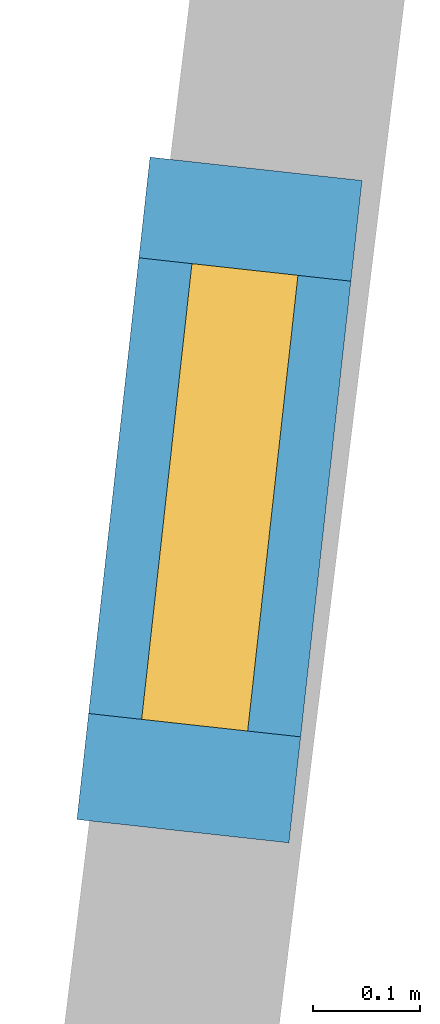
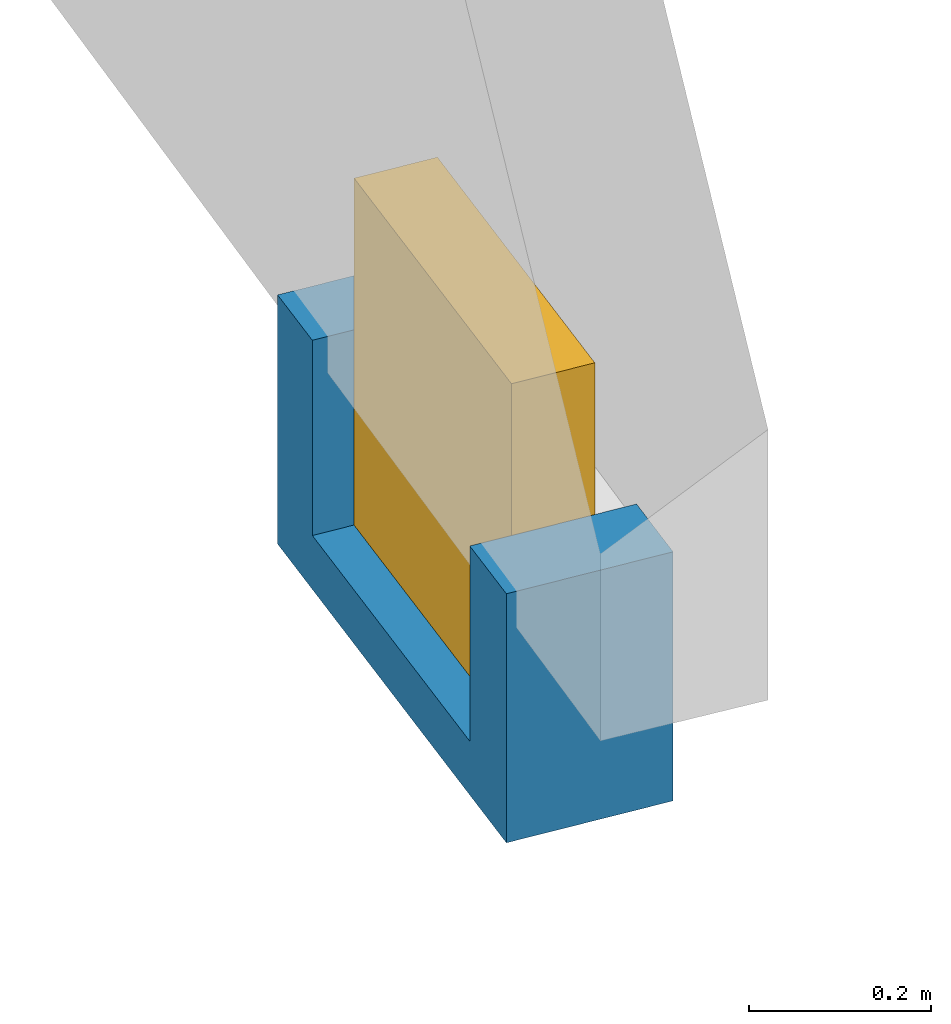
# One storey, part 27 of 27: 1 wall, 1 window, 1 opening.
"""IFC2X3 building model written with IfcOpenShell, lengths in metres."""

import ifcopenshell
import ifcopenshell.guid

model = None  # the IFC model being written
_history = None  # IfcOwnerHistory: only IFC2X3 demands one
_inside = {}  # id of a spatial element -> (the spatial element, [elements in it])
_under = {}  # id of a project, library or spatial element -> (it, [spatial elements below it])
_declared = {}  # id of a project -> (the project, [libraries it declares])
_typed = {}  # id of a type object -> (the type object, [elements of that type])
_made_of = {}  # id of a material, layer set ... -> (it, [elements and type objects made of it])


def new_model(schema):
    """Start an empty IFC model of exactly this schema.

    Asked for "IFC4X3", IfcOpenShell would pick the latest addendum, in which some entities
    have other attributes; the version numbers below select the first issue.
    IFC2X3 requires an IfcOwnerHistory on every rooted entity: one is made here for all.
    """
    global model, _history
    if schema == "IFC4X3":
        model = ifcopenshell.file(schema_version=(4, 3, 0, 0))
    else:
        model = ifcopenshell.file(schema=schema)
    _inside.clear()
    _under.clear()
    _declared.clear()
    _typed.clear()
    _made_of.clear()
    _history = None
    if model.schema == "IFC2X3":
        org = make("IfcOrganization", Name="unknown")
        user = make(
            "IfcPersonAndOrganization",
            ThePerson=make("IfcPerson", FamilyName="unknown"),
            TheOrganization=org,
        )
        app = make(
            "IfcApplication",
            ApplicationDeveloper=org,
            Version="unknown",
            ApplicationFullName="unknown",
            ApplicationIdentifier="unknown",
        )
        _history = make(
            "IfcOwnerHistory",
            OwningUser=user,
            OwningApplication=app,
            ChangeAction="ADDED",
            CreationDate=0,
        )
    return model


def make(cls, **values):
    """One entity of the class cls with the attributes given. An attribute that is None is left unset."""
    return model.create_entity(
        cls, **{name: value for name, value in values.items() if value is not None}
    )


def entity(cls, *values):
    """Any entity or typed value of the class cls, its attributes in the order of the schema. None: left unset."""
    e = model.create_entity(cls)
    for i, value in enumerate(values):
        if value is not None:
            e[i] = value
    return e


def rooted(cls, **values):
    """An entity with a GlobalId (a new one), such as an element, a storey or a relation."""
    return make(cls, GlobalId=ifcopenshell.guid.new(), OwnerHistory=_history, **values)


def si_unit(unit_type, name, prefix=None):
    """IfcSIUnit, for example si_unit("LENGTHUNIT", "METRE", prefix="MILLI")."""
    return make("IfcSIUnit", UnitType=unit_type, Prefix=prefix, Name=name)


def converted_unit(unit_type, name, factor, base, dimensions=None, offset=None):
    """IfcConversionBasedUnit, such as the inch: factor (a typed value) times the base unit."""
    return make(
        "IfcConversionBasedUnit"
        if offset is None
        else "IfcConversionBasedUnitWithOffset",
        ConversionOffset=offset,
        Dimensions=None
        if dimensions is None
        else entity("IfcDimensionalExponents", *dimensions),
        UnitType=unit_type,
        Name=name,
        ConversionFactor=make(
            "IfcMeasureWithUnit", ValueComponent=factor, UnitComponent=base
        ),
    )


def derived_unit(unit_type, elements):
    """IfcDerivedUnit: a product of units, each with its exponent."""
    return make(
        "IfcDerivedUnit",
        Elements=[
            make("IfcDerivedUnitElement", Unit=unit, Exponent=power)
            for unit, power in elements
        ],
        UnitType=unit_type,
    )


def assignment(units):
    """IfcUnitAssignment: the units of a project."""
    return None if units is None else make("IfcUnitAssignment", Units=units)


def point(xyz):
    """IfcCartesianPoint."""
    return None if xyz is None else make("IfcCartesianPoint", Coordinates=xyz)


def direction(xyz):
    """IfcDirection."""
    return None if xyz is None else make("IfcDirection", DirectionRatios=xyz)


def frame(location, z_axis=None, x_axis=None):
    """IfcAxis2Placement3D, a coordinate frame: its origin and axes. An axis left out is left unset."""
    return make(
        "IfcAxis2Placement3D",
        Location=point(location),
        Axis=direction(z_axis),
        RefDirection=direction(x_axis),
    )


def frame_2d(location, x_axis=None):
    """IfcAxis2Placement2D, a coordinate frame in the plane: its origin and x axis."""
    return make(
        "IfcAxis2Placement2D", Location=point(location), RefDirection=direction(x_axis)
    )


def origin():
    """The frame at (0, 0, 0) with its axes left unset."""
    return frame((0.0, 0.0, 0.0))


def origin_2d_with_axis():
    """The frame at (0, 0) in the plane with the x axis (1, 0) written out."""
    return frame_2d((0.0, 0.0), x_axis=(1.0, 0.0))


def place(relative_to, where):
    """IfcLocalPlacement: puts the frame where relative to a parent placement (None: the world)."""
    return make(
        "IfcLocalPlacement", PlacementRelTo=relative_to, RelativePlacement=where
    )


def context(
    kind, dimensions, precision=None, world=None, true_north=None, identifier=None
):
    """IfcGeometricRepresentationContext, for example the 3D "Model" context."""
    return make(
        "IfcGeometricRepresentationContext",
        ContextIdentifier=identifier,
        ContextType=kind,
        CoordinateSpaceDimension=dimensions,
        Precision=precision,
        WorldCoordinateSystem=world,
        TrueNorth=true_north,
    )


def subcontext(parent, identifier, kind, view, scale=None):
    """IfcGeometricRepresentationSubContext, for example "Body" below "Model"."""
    return make(
        "IfcGeometricRepresentationSubContext",
        ContextIdentifier=identifier,
        ContextType=kind,
        ParentContext=parent,
        TargetScale=scale,
        TargetView=view,
    )


def project(units=None, contexts=None):
    """IfcProject with its units and contexts."""
    return rooted(
        "IfcProject",
        Name="project",
        RepresentationContexts=contexts,
        UnitsInContext=assignment(units),
    )


def spatial(cls, under=None, at=None, **own):
    """A site, building, storey or space (cls), placed at a placement, below another one or the project."""
    s = rooted(cls, ObjectPlacement=at, **own)
    if under is not None:
        _under.setdefault(under.id(), (under, []))[1].append(s)
    return s


def polyline(points):
    """IfcPolyline through the points."""
    return make("IfcPolyline", Points=[point(p) for p in points])


def profile(cls, at=None, kind="AREA", **sizes):
    """A parametric profile (cls). Its sizes go by their IFC names, for example OverallWidth=200.0."""
    return make(cls, ProfileType=kind, Position=at, **sizes)


def rectangle(**sizes):
    """IfcRectangleProfileDef."""
    return profile("IfcRectangleProfileDef", **sizes)


def outline(outer, holes=None, kind="AREA"):
    """IfcArbitraryClosedProfileDef: a profile drawn as a closed curve; with holes, ...WithVoids."""
    if holes is None:
        return make("IfcArbitraryClosedProfileDef", ProfileType=kind, OuterCurve=outer)
    return make(
        "IfcArbitraryProfileDefWithVoids",
        ProfileType=kind,
        OuterCurve=outer,
        InnerCurves=holes,
    )


def extrude(swept, where, along, depth):
    """IfcExtrudedAreaSolid: the profile swept, set in the frame where, extruded along a direction by depth."""
    return make(
        "IfcExtrudedAreaSolid",
        SweptArea=swept,
        Position=where,
        ExtrudedDirection=direction(along),
        Depth=depth,
    )


def shape(context_of_items, identifier, shape_type, items):
    """IfcShapeRepresentation: the items that make up one representation, for example the "Body"."""
    return make(
        "IfcShapeRepresentation",
        ContextOfItems=context_of_items,
        RepresentationIdentifier=identifier,
        RepresentationType=shape_type,
        Items=items,
    )


def source(mapping_origin, context_of_items, identifier, shape_type, items):
    """IfcRepresentationMap: a shape defined once, which mapped items show again and again."""
    return make(
        "IfcRepresentationMap",
        MappingOrigin=mapping_origin,
        MappedRepresentation=shape(context_of_items, identifier, shape_type, items),
    )


def transform(
    local_origin,
    x_axis=None,
    y_axis=None,
    z_axis=None,
    scale=None,
    scale2=None,
    scale3=None,
    uniform=True,
):
    """IfcCartesianTransformationOperator3D, or its non-uniform kind. x_axis, y_axis, z_axis: its Axis1, 2, 3."""
    if uniform:
        return make(
            "IfcCartesianTransformationOperator3D",
            Axis1=direction(x_axis),
            Axis2=direction(y_axis),
            LocalOrigin=point(local_origin),
            Scale=scale,
            Axis3=direction(z_axis),
        )
    return make(
        "IfcCartesianTransformationOperator3DnonUniform",
        Axis1=direction(x_axis),
        Axis2=direction(y_axis),
        LocalOrigin=point(local_origin),
        Scale=scale,
        Axis3=direction(z_axis),
        Scale2=scale2,
        Scale3=scale3,
    )


def mapped(mapping_source, mapping_target):
    """IfcMappedItem: shows the shape of a source again, moved by a transform."""
    return make(
        "IfcMappedItem", MappingSource=mapping_source, MappingTarget=mapping_target
    )


def material(Name=None, Category=None):
    """IfcMaterial."""
    return make("IfcMaterial", Name=Name, Category=Category)


def layer(
    of_material, thickness, ventilated=None, Name=None, Category=None, Priority=None
):
    """IfcMaterialLayer: one layer of a wall or slab, of a material (None: an air gap)."""
    return make(
        "IfcMaterialLayer",
        Material=of_material,
        LayerThickness=thickness,
        IsVentilated=ventilated,
        Name=Name,
        Category=Category,
        Priority=Priority,
    )


def layer_set(layers, Name=None):
    """IfcMaterialLayerSet."""
    return make("IfcMaterialLayerSet", MaterialLayers=layers, LayerSetName=Name)


def layer_usage(for_layer_set, set_direction, sense, offset, extent=None):
    """IfcMaterialLayerSetUsage: how a layer set lies in its element."""
    return make(
        "IfcMaterialLayerSetUsage",
        ForLayerSet=for_layer_set,
        LayerSetDirection=set_direction,
        DirectionSense=sense,
        OffsetFromReferenceLine=offset,
        ReferenceExtent=extent,
    )


def made_of(thing, what):
    """Note that an element or type object is made of a material, layer set ...; save() writes the relation."""
    if what is not None:
        _made_of.setdefault(what.id(), (what, []))[1].append(thing)
    return thing


def type_object(cls, material=None, **own):
    """A type object (cls), such as IfcWallType, which elements share."""
    return made_of(rooted(cls, **own), material)


def type_shapes(of_type, sources):
    """Give a type object the sources (RepresentationMaps) that its elements show as mapped items."""
    of_type.RepresentationMaps = sources


def element(
    cls,
    number,
    at=None,
    inside=None,
    cuts=None,
    type_object=None,
    material=None,
    context=None,
    identifier="Body",
    shape_type=None,
    held_by="IfcProductDefinitionShape",
    body=None,
    shapes=None,
    **own,
):
    """One element of the class cls, such as IfcWall. Its Tag is "e" and its number.

    at: its placement. inside: the storey or other place that contains it. cuts: it is an
    opening in that element (IfcRelVoidsElement). A single representation is given by context,
    identifier, shape_type and body (its items); several are given by shapes. held_by: the class
    of the entity that holds the representations. save() writes the other relations.
    """
    e = rooted(cls, Tag="e%d" % number, ObjectPlacement=at, **own)
    if body is not None:
        shapes = [shape(context, identifier, shape_type, body)]
    if shapes is not None:
        e.Representation = make(held_by, Representations=shapes)
    if inside is not None:
        _inside.setdefault(inside.id(), (inside, []))[1].append(e)
    if cuts is not None:
        rooted(
            "IfcRelVoidsElement", RelatingBuildingElement=cuts, RelatedOpeningElement=e
        )
    if type_object is not None:
        _typed.setdefault(type_object.id(), (type_object, []))[1].append(e)
    return made_of(e, material)


def fill(opening, filler):
    """IfcRelFillsElement: the door or window that sits in an opening."""
    return rooted(
        "IfcRelFillsElement",
        RelatingOpeningElement=opening,
        RelatedBuildingElement=filler,
    )


def aggregate(whole, parts):
    """IfcRelAggregates: a whole, such as a stair, and the parts it consists of."""
    return rooted("IfcRelAggregates", RelatingObject=whole, RelatedObjects=parts)


def save(model, path):
    """Write the relations noted so far, then the file.

    IfcRelAggregates (storeys below a building ...), IfcRelContainedInSpatialStructure (elements
    in a storey), IfcRelDefinesByType, IfcRelAssociatesMaterial and IfcRelDeclares: one each for
    every whole, place, type object, material and project.
    """
    for whole, parts in _under.values():
        aggregate(whole, parts)
    for where, things in _inside.values():
        rooted(
            "IfcRelContainedInSpatialStructure",
            RelatedElements=things,
            RelatingStructure=where,
        )
    for kind, things in _typed.values():
        rooted("IfcRelDefinesByType", RelatedObjects=things, RelatingType=kind)
    for what, things in _made_of.values():
        rooted("IfcRelAssociatesMaterial", RelatedObjects=things, RelatingMaterial=what)
    for by, libraries in _declared.values():
        rooted("IfcRelDeclares", RelatingContext=by, RelatedDefinitions=libraries)
    model.write(path)


model = new_model("IFC2X3")

# Units and contexts
model_context = context("Model", 3, precision=1e-05, world=origin(), true_north=direction((0.0, 1.0)))
body_context = subcontext(model_context, "Body", "Model", "MODEL_VIEW")
ifc_project = project(units=[si_unit("LENGTHUNIT", "METRE"), si_unit("AREAUNIT", "SQUARE_METRE"), si_unit("VOLUMEUNIT", "CUBIC_METRE"), converted_unit("PLANEANGLEUNIT", "DEGREE", entity("IfcRatioMeasure", 0.0174532925199433), si_unit("PLANEANGLEUNIT", "RADIAN"), dimensions=[0, 0, 0, 0, 0, 0, 0]), si_unit("MASSUNIT", "GRAM", prefix="KILO"), derived_unit("MASSDENSITYUNIT", [(si_unit("MASSUNIT", "GRAM", prefix="KILO"), 1), (si_unit("LENGTHUNIT", "METRE"), -3)]), derived_unit("MOMENTOFINERTIAUNIT", [(si_unit("LENGTHUNIT", "METRE"), 4)]), si_unit("TIMEUNIT", "SECOND"), si_unit("FREQUENCYUNIT", "HERTZ"), si_unit("THERMODYNAMICTEMPERATUREUNIT", "DEGREE_CELSIUS"), derived_unit("THERMALTRANSMITTANCEUNIT", [(si_unit("MASSUNIT", "GRAM", prefix="KILO"), 1), (si_unit("THERMODYNAMICTEMPERATUREUNIT", "KELVIN"), -1), (si_unit("TIMEUNIT", "SECOND"), -3)]), derived_unit("VOLUMETRICFLOWRATEUNIT", [(si_unit("LENGTHUNIT", "METRE"), 3), (si_unit("TIMEUNIT", "SECOND"), -1)]), si_unit("ELECTRICCURRENTUNIT", "AMPERE"), si_unit("ELECTRICVOLTAGEUNIT", "VOLT"), si_unit("POWERUNIT", "WATT"), si_unit("FORCEUNIT", "NEWTON", prefix="KILO"), si_unit("ILLUMINANCEUNIT", "LUX"), si_unit("LUMINOUSFLUXUNIT", "LUMEN"), si_unit("LUMINOUSINTENSITYUNIT", "CANDELA"), derived_unit("USERDEFINED", [(si_unit("MASSUNIT", "GRAM", prefix="KILO"), -1), (si_unit("LENGTHUNIT", "METRE"), -2), (si_unit("TIMEUNIT", "SECOND"), 3), (si_unit("LUMINOUSFLUXUNIT", "LUMEN"), 1)]), derived_unit("LINEARVELOCITYUNIT", [(si_unit("LENGTHUNIT", "METRE"), 1), (si_unit("TIMEUNIT", "SECOND"), -1)]), si_unit("PRESSUREUNIT", "PASCAL"), derived_unit("USERDEFINED", [(si_unit("LENGTHUNIT", "METRE"), -2), (si_unit("MASSUNIT", "GRAM", prefix="KILO"), 1), (si_unit("TIMEUNIT", "SECOND"), -2)]), derived_unit("LINEARFORCEUNIT", [(si_unit("MASSUNIT", "GRAM", prefix="KILO"), 1), (si_unit("LENGTHUNIT", "METRE"), 1), (si_unit("TIMEUNIT", "SECOND"), -2), (si_unit("LENGTHUNIT", "METRE"), -1)]), derived_unit("PLANARFORCEUNIT", [(si_unit("MASSUNIT", "GRAM", prefix="KILO"), 1), (si_unit("LENGTHUNIT", "METRE"), 1), (si_unit("TIMEUNIT", "SECOND"), -2), (si_unit("LENGTHUNIT", "METRE"), -2)])], contexts=[model_context])

# Site, building, storey
placement = place(None, origin())
site = spatial("IfcSite", under=ifc_project, at=placement, CompositionType="ELEMENT")
building = spatial("IfcBuilding", under=site, at=placement, CompositionType="ELEMENT")
storey_placement = place(placement, frame((0.0, 0.0, -61.043098449707)))
storey = spatial("IfcBuildingStorey", under=building, at=storey_placement, Name="level_-61.043098", CompositionType="ELEMENT", Elevation=-61.043098449707)

# Wall, opening, window
ifc_material_1 = material(Name="Default wall")
ifc_layer = layer(ifc_material_1, 0.2)
ifc_layer_set = layer_set([ifc_layer], Name="wall_thickness_0.2000")
ifc_layer_usage = layer_usage(ifc_layer_set, "AXIS2", "POSITIVE", -0.1)
wall_type = type_object("IfcWallType", Name="wall_thickness_0.2000", PredefinedType="STANDARD", material=ifc_layer_set)
wall_placement = place(storey_placement, frame((-51.721368227383, 1.53429862089677, 0.0), z_axis=(0.0, 0.0, 1.0), x_axis=(-0.109643565573752, -0.993970969660721, 0.0)))
wall = element("IfcWallStandardCase", 1, at=wall_placement, inside=storey, type_object=wall_type, material=ifc_layer_usage, Name="Wall:207", ObjectType="Wall", context=body_context, shape_type="SweptSolid", body=[
    extrude(outline(polyline([(0.624999937945219, -0.1), (0.624999937945219, 0.1), (0.0, 0.1), (0.0, -0.1), (0.624999937945219, -0.1)])), origin(), (0.0, 0.0, 1.0), 0.333827972412109),
])
opening_placement = place(wall_placement, frame((0.0950003013175582, -0.1, 0.0721473693847656)))
opening = element("IfcOpeningElement", 2, at=opening_placement, cuts=wall, Name="Opening : 430 x 465 : 14", ObjectType="Opening", context=body_context, shape_type="SweptSolid", body=[
    extrude(rectangle(XDim=0.43, YDim=0.465, at=frame_2d((0.2325, 0.215), x_axis=(0.0, 1.0))), frame((0.0, 0.0, 0.0), z_axis=(0.0, 1.0, 0.0), x_axis=(0.0, 0.0, 1.0)), (0.0, 0.0, 1.0), 0.2),
])
ifc_material_2 = material(Name="Window Default")
window_style = type_object("IfcWindowStyle", Name="Window : 430 x 465mm", ConstructionType="NOTDEFINED", OperationType="NOTDEFINED", ParameterTakesPrecedence=False, Sizeable=False, material=ifc_material_2)
shared_shape = source(origin(), body_context, "Body", "SweptSolid", [
    extrude(rectangle(XDim=0.1, YDim=0.43, at=origin_2d_with_axis()), frame((0.215, 0.1, 0.0), z_axis=(0.0, 0.0, 1.0), x_axis=(0.0, 1.0, 0.0)), (0.0, 0.0, 1.0), 0.465),
])
type_shapes(window_style, [shared_shape])
window_placement = place(opening_placement, origin())
window = element("IfcWindow", 3, at=window_placement, inside=storey, type_object=window_style, Name="Window : 430 x 465mm : 12", ObjectType="Window : 430 x 465mm", OverallHeight=0.465, OverallWidth=0.43, context=body_context, shape_type="MappedRepresentation", body=[
    mapped(shared_shape, transform((0.0, 0.0, 0.0), scale=1.0)),
])
fill(opening, window)

save(model, "model.ifc")
